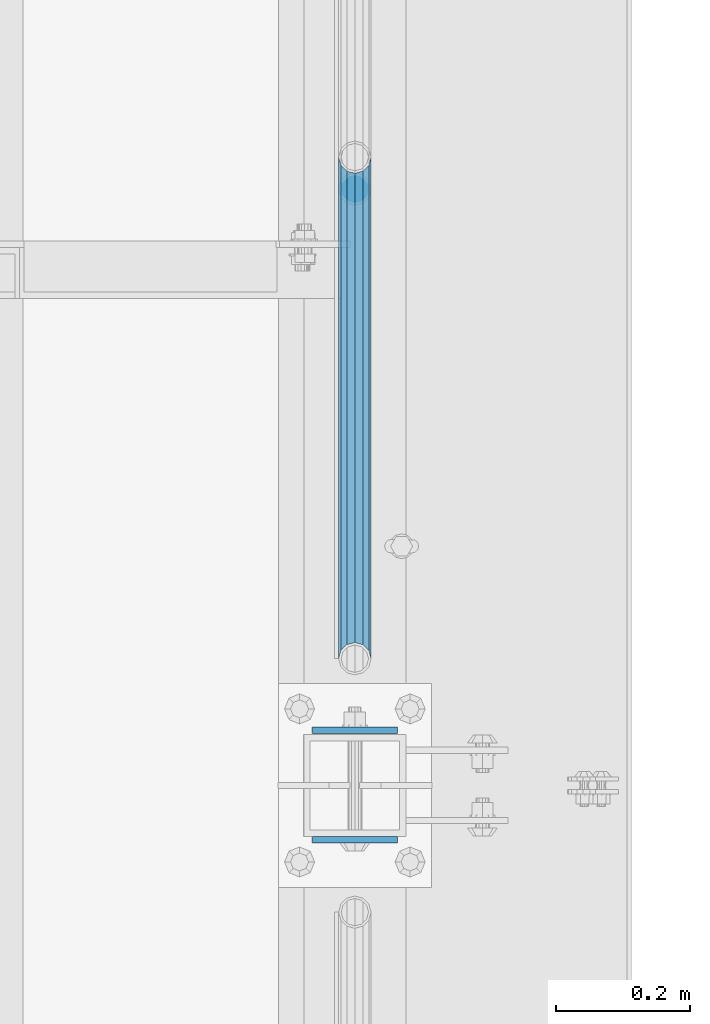
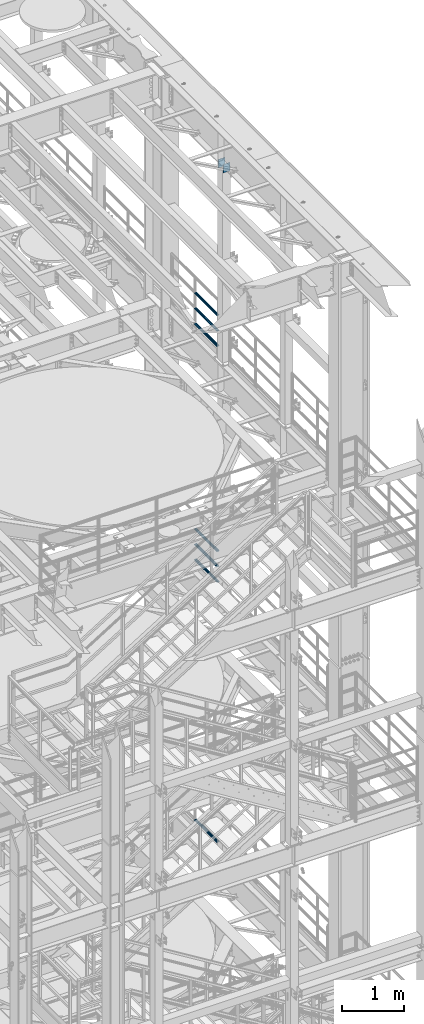
# One storey, part 1267 of 1876: 9 beams, 4 elements without a shape of their own.
"""IFC2X3 building model written with IfcOpenShell, lengths in millimetres."""

from ifc_helpers import new_model, si_unit, frame, origin_with_axes, place, context, subcontext, project, spatial, faceted_brep, material, type_object, element, aggregate, save


model = new_model("IFC2X3")

# Units and contexts
model_context = context("Model", 3, precision=1e-05, world=origin_with_axes())
body_context = subcontext(model_context, "Body", "Model", "MODEL_VIEW")
ifc_project = project(units=[si_unit("LENGTHUNIT", "METRE", prefix="MILLI"), si_unit("AREAUNIT", "SQUARE_METRE"), si_unit("VOLUMEUNIT", "CUBIC_METRE"), si_unit("MASSUNIT", "GRAM", prefix="KILO"), si_unit("TIMEUNIT", "SECOND"), si_unit("PLANEANGLEUNIT", "RADIAN"), si_unit("SOLIDANGLEUNIT", "STERADIAN"), si_unit("THERMODYNAMICTEMPERATUREUNIT", "DEGREE_CELSIUS"), si_unit("LUMINOUSINTENSITYUNIT", "LUMEN")], contexts=[model_context])

# Site, building, storey
site_placement = place(None, origin_with_axes())
site = spatial("IfcSite", under=ifc_project, at=site_placement, CompositionType="ELEMENT")
building_placement = place(site_placement, origin_with_axes())
building = spatial("IfcBuilding", under=site, at=building_placement, Name="Undefined", CompositionType="ELEMENT")
storey_placement = place(building_placement, origin_with_axes())
storey = spatial("IfcBuildingStorey", under=building, at=storey_placement, Name="Undefined", CompositionType="ELEMENT", Elevation=0.0)

# Assembly, beams
assembly_1_placement = place(storey_placement, origin_with_axes())
assembly_1 = element("IfcElementAssembly", 1, at=assembly_1_placement, inside=storey, Name="RAIL", AssemblyPlace="NOTDEFINED", PredefinedType="RIGID_FRAME")
ifc_material_1 = material()
beam_type_1 = type_object("IfcBeamType", Name="PIPE1-1/2SCH40", PredefinedType="NOTDEFINED")
beam_1_placement = place(assembly_1_placement, frame((7620.0, 430.212499999997, 18145.125), z_axis=(0.0, 0.0, 1.0), x_axis=(0.0, -1.0, 0.0)))
beam_1 = element("IfcBeam", 2, at=beam_1_placement, type_object=beam_type_1, material=ifc_material_1, Name="RAIL", ObjectType="PIPE1-1/2SCH40", context=body_context, shape_type="Brep", body=[
    faceted_brep([(728.085307006683, -12.0649999999996, 20.8971929933177), (728.085307006683, -12.0649999999996, 15.8661214311796), (727.591878568821, -10.2235000000001, 17.7076214311819), (724.852500000002, 0.0, 20.4470000000001), (724.852500000002, 0.0, 24.130000000001), (727.591878568821, 10.2235000000001, 17.7076214311819), (728.085307006683, 12.0649999999996, 15.8661214311796), (728.085307006683, 12.0649999999996, 20.8971929933177), (748.982500000002, 24.1300000000001, 0.0), (736.917500000002, 20.8971929933186, 12.0649999999987), (736.917500000002, 20.8971929933186, -12.0649999999987), (733.727928437864, 17.7076214311801, 10.2235000000001), (736.467307006683, 20.4470000000001, 0.0), (733.727928437864, 17.7076214311801, -10.2235000000001), (728.085307006683, 12.0649999999996, -15.8661214311796), (728.085307006683, 12.0649999999996, -20.8971929933177), (727.591878568821, 10.2235000000001, -17.7076214311819), (724.852500000002, 0.0, -20.4470000000001), (724.852500000002, 0.0, -24.130000000001), (728.085307006683, -12.0649999999996, -15.8661214311796), (728.085307006683, -12.0649999999996, -20.8971929933177), (727.591878568821, -10.2235000000001, -17.7076214311819), (748.982500000002, -24.1300000000001, 0.0), (736.917500000002, -20.8971929933186, -12.0649999999987), (736.917500000002, -20.8971929933186, 12.0649999999987), (733.727928437864, -17.7076214311801, -10.2235000000001), (736.467307006683, -20.4470000000001, 0.0), (733.727928437864, -17.7076214311801, 10.2235000000001), (12.0650000000064, -20.8971929933177, -12.0649999999987), (20.8971929933249, -12.0650000000005, -20.8971929933177), (0.0, 24.1299999999992, 0.0), (12.0650000000064, 20.8971929933177, -12.0649999999987), (12.0650000000064, 20.8971929933177, 12.0649999999987), (20.8971929933249, 12.0650000000005, 20.8971929933177), (24.1300000000064, 0.0, 24.130000000001), (20.8971929933249, 12.0650000000005, -20.8971929933177), (24.1300000000063, 0.0, -24.130000000001), (24.1300000000063, 0.0, -20.4470000000001), (20.8971929933249, -12.0650000000005, -15.8661214311796), (21.3906214311868, -10.2235000000001, -17.7076214311819), (21.3906214311868, 10.2235000000001, -17.7076214311819), (20.8971929933249, 12.0650000000005, -15.8661214311796), (15.2545715621445, 17.7076214311801, -10.2235000000001), (12.5151929933249, 20.4470000000001, 0.0), (15.2545715621445, 17.7076214311801, 10.2235000000001), (20.8971929933249, 12.0650000000005, 15.8661214311796), (21.3906214311868, 10.2235000000001, 17.7076214311819), (24.1300000000064, 0.0, 20.4470000000001), (21.3906214311868, -10.2235000000001, 17.7076214311819), (20.8971929933249, -12.0650000000005, 15.8661214311796), (20.8971929933249, -12.0650000000005, 20.8971929933177), (12.0650000000064, -20.8971929933177, 12.0649999999987), (0.0, -24.1299999999992, 0.0), (15.2545715621445, -17.7076214311801, 10.2235000000001), (12.5151929933249, -20.4470000000001, 0.0), (15.2545715621445, -17.7076214311801, -10.2235000000001)], [[[0, 1, 2, 3, 4]], [[4, 3, 5, 6, 7]], [[8, 9, 10]], [[7, 6, 11, 12, 13, 14, 15, 10, 9]], [[16, 17, 18, 15, 14]], [[19, 20, 18, 17, 21]], [[22, 23, 24]], [[24, 23, 20, 19, 25, 26, 27, 1, 0]], [[28, 29, 20, 23]], [[30, 31, 32]], [[33, 34, 4, 7]], [[32, 33, 7, 9]], [[30, 32, 9, 8]], [[31, 30, 8, 10]], [[35, 31, 10, 15]], [[36, 35, 15, 18]], [[29, 36, 18, 20]], [[37, 36, 29, 38, 39]], [[40, 41, 35, 36, 37]], [[32, 31, 35, 41, 42, 43, 44, 45, 33]], [[33, 45, 46, 47, 34]], [[34, 47, 48, 49, 50]], [[34, 50, 0, 4]], [[50, 51, 24, 0]], [[51, 52, 22, 24]], [[52, 28, 23, 22]], [[51, 28, 52]], [[50, 49, 53, 54, 55, 38, 29, 28, 51]], [[55, 54, 26, 25]], [[21, 39, 38, 55, 25, 19]], [[37, 39, 21, 17]], [[40, 37, 17, 16]], [[42, 41, 40, 16, 14, 13]], [[43, 42, 13, 12]], [[44, 43, 12, 11]], [[5, 46, 45, 44, 11, 6]], [[47, 46, 5, 3]], [[48, 47, 3, 2]], [[53, 49, 48, 2, 1, 27]], [[54, 53, 27, 26]]]),
])
beam_2_placement = place(assembly_1_placement, frame((7620.0, -318.770000000003, 18449.925), z_axis=(0.0, 0.0, -1.0), x_axis=(0.0, 1.0, 0.0)))
beam_2 = element("IfcBeam", 3, at=beam_2_placement, type_object=beam_type_1, material=ifc_material_1, Name="RAIL", ObjectType="PIPE1-1/2SCH40", context=body_context, shape_type="Brep", body=[
    faceted_brep([(0.0, 24.1299999999992, 0.0), (12.0650000000064, 20.8971929933177, -12.0649999999987), (12.0650000000064, 20.8971929933177, 12.0649999999987), (12.0650000000064, -20.8971929933177, 12.0649999999987), (12.0650000000064, -20.8971929933177, -12.0649999999987), (0.0, -24.1299999999992, 0.0), (20.8971929933249, -12.0650000000005, 20.8971929933177), (20.8971929933249, -12.0650000000005, 15.8661214311796), (15.2545715621445, -17.7076214311801, 10.2235000000001), (12.5151929933249, -20.4470000000001, 0.0), (15.2545715621445, -17.7076214311801, -10.2235000000001), (20.8971929933249, -12.0650000000005, -15.8661214311796), (20.8971929933249, -12.0650000000005, -20.8971929933177), (24.1300000000063, 0.0, -20.4470000000001), (24.1300000000063, 0.0, -24.130000000001), (21.3906214311868, -10.2235000000001, -17.7076214311819), (21.3906214311868, 10.2235000000001, -17.7076214311819), (20.8971929933249, 12.0650000000005, -15.8661214311796), (20.8971929933249, 12.0650000000005, -20.8971929933177), (15.2545715621445, 17.7076214311801, -10.2235000000001), (12.5151929933249, 20.4470000000001, 0.0), (15.2545715621445, 17.7076214311801, 10.2235000000001), (20.8971929933249, 12.0650000000005, 15.8661214311796), (20.8971929933249, 12.0650000000005, 20.8971929933177), (21.3906214311868, 10.2235000000001, 17.7076214311819), (24.1300000000064, 0.0, 20.4470000000001), (24.1300000000064, 0.0, 24.130000000001), (21.3906214311868, -10.2235000000001, 17.7076214311819), (748.982500000002, 24.1300000000001, 0.0), (736.917500000002, 20.8971929933186, -12.0649999999987), (728.085307006683, 12.0649999999996, -20.8971929933177), (748.982500000002, -24.1300000000001, 0.0), (736.917500000002, -20.8971929933186, -12.0649999999987), (736.917500000002, -20.8971929933186, 12.0649999999987), (728.085307006683, -12.0649999999996, 20.8971929933177), (728.085307006683, -12.0649999999996, -20.8971929933177), (724.852500000002, 0.0, -24.130000000001), (727.591878568821, 10.2235000000001, -17.7076214311819), (724.852500000002, 0.0, -20.4470000000001), (728.085307006683, 12.0649999999996, -15.8661214311796), (728.085307006683, -12.0649999999996, -15.8661214311796), (727.591878568821, -10.2235000000001, -17.7076214311819), (733.727928437864, -17.7076214311801, -10.2235000000001), (736.467307006683, -20.4470000000001, 0.0), (733.727928437864, -17.7076214311801, 10.2235000000001), (728.085307006683, -12.0649999999996, 15.8661214311796), (727.591878568821, -10.2235000000001, 17.7076214311819), (724.852500000002, 0.0, 20.4470000000001), (724.852500000002, 0.0, 24.130000000001), (728.085307006683, 12.0649999999996, 20.8971929933177), (736.917500000002, 20.8971929933186, 12.0649999999987), (728.085307006683, 12.0649999999996, 15.8661214311796), (733.727928437864, 17.7076214311801, 10.2235000000001), (736.467307006683, 20.4470000000001, 0.0), (733.727928437864, 17.7076214311801, -10.2235000000001), (727.591878568821, 10.2235000000001, 17.7076214311819)], [[[0, 1, 2]], [[3, 4, 5]], [[6, 7, 8, 9, 10, 11, 12, 4, 3]], [[13, 14, 12, 11, 15]], [[16, 17, 18, 14, 13]], [[2, 1, 18, 17, 19, 20, 21, 22, 23]], [[23, 22, 24, 25, 26]], [[26, 25, 27, 7, 6]], [[1, 0, 28, 29]], [[18, 1, 29, 30]], [[31, 32, 33]], [[6, 3, 33, 34]], [[3, 5, 31, 33]], [[5, 4, 32, 31]], [[4, 12, 35, 32]], [[12, 14, 36, 35]], [[14, 18, 30, 36]], [[37, 38, 36, 30, 39]], [[40, 35, 36, 38, 41]], [[33, 32, 35, 40, 42, 43, 44, 45, 34]], [[34, 45, 46, 47, 48]], [[26, 6, 34, 48]], [[2, 23, 49, 50]], [[23, 26, 48, 49]], [[0, 2, 50, 28]], [[28, 50, 29]], [[49, 51, 52, 53, 54, 39, 30, 29, 50]], [[48, 47, 55, 51, 49]], [[25, 24, 55, 47]], [[55, 24, 22, 21, 52, 51]], [[21, 20, 53, 52]], [[20, 19, 54, 53]], [[19, 17, 16, 37, 39, 54]], [[16, 13, 38, 37]], [[13, 15, 41, 38]], [[41, 15, 11, 10, 42, 40]], [[10, 9, 43, 42]], [[9, 8, 44, 43]], [[8, 7, 27, 46, 45, 44]], [[27, 25, 47, 46]]]),
])
beam_3_placement = place(assembly_1_placement, frame((7620.0, -318.770000000003, 18754.725), z_axis=(0.0, 0.0, -1.0), x_axis=(0.0, 1.0, 0.0)))
beam_3 = element("IfcBeam", 4, at=beam_3_placement, type_object=beam_type_1, material=ifc_material_1, Name="RAIL", ObjectType="PIPE1-1/2SCH40", context=body_context, shape_type="Brep", body=[
    faceted_brep([(0.0, 24.1299999999992, 0.0), (12.0650000000064, 20.8971929933177, -12.0649999999987), (12.0650000000064, 20.8971929933177, 12.0649999999987), (12.0650000000064, -20.8971929933177, 12.0649999999987), (12.0650000000064, -20.8971929933177, -12.0649999999987), (0.0, -24.1299999999992, 0.0), (20.8971929933249, -12.0650000000005, 20.8971929933177), (20.8971929933249, -12.0650000000005, 15.8661214311796), (15.2545715621445, -17.7076214311801, 10.2235000000001), (12.5151929933249, -20.4470000000001, 0.0), (15.2545715621445, -17.7076214311801, -10.2235000000001), (20.8971929933249, -12.0650000000005, -15.8661214311796), (20.8971929933249, -12.0650000000005, -20.8971929933177), (24.1300000000063, 0.0, -20.4470000000001), (24.1300000000063, 0.0, -24.130000000001), (21.3906214311868, -10.2235000000001, -17.7076214311819), (21.3906214311868, 10.2235000000001, -17.7076214311819), (20.8971929933249, 12.0650000000005, -15.8661214311796), (20.8971929933249, 12.0650000000005, -20.8971929933177), (15.2545715621445, 17.7076214311801, -10.2235000000001), (12.5151929933249, 20.4470000000001, 0.0), (15.2545715621445, 17.7076214311801, 10.2235000000001), (20.8971929933249, 12.0650000000005, 15.8661214311796), (20.8971929933249, 12.0650000000005, 20.8971929933177), (21.3906214311868, 10.2235000000001, 17.7076214311819), (24.1300000000064, 0.0, 20.4470000000001), (24.1300000000064, 0.0, 24.130000000001), (21.3906214311868, -10.2235000000001, 17.7076214311819), (748.982500000002, 24.1300000000001, 0.0), (736.917500000002, 20.8971929933186, -12.0649999999987), (728.085307006683, 12.0649999999996, -20.8971929933177), (748.982500000002, -24.1300000000001, 0.0), (736.917500000002, -20.8971929933186, -12.0649999999987), (736.917500000002, -20.8971929933186, 12.0649999999987), (728.085307006683, -12.0649999999996, 20.8971929933177), (728.085307006683, -12.0649999999996, -20.8971929933177), (724.852500000002, 0.0, -24.130000000001), (727.591878568821, 10.2235000000001, -17.7076214311819), (724.852500000002, 0.0, -20.4470000000001), (728.085307006683, 12.0649999999996, -15.8661214311796), (728.085307006683, -12.0649999999996, -15.8661214311796), (727.591878568821, -10.2235000000001, -17.7076214311819), (733.727928437864, -17.7076214311801, -10.2235000000001), (736.467307006683, -20.4470000000001, 0.0), (733.727928437864, -17.7076214311801, 10.2235000000001), (728.085307006683, -12.0649999999996, 15.8661214311796), (727.591878568821, -10.2235000000001, 17.7076214311819), (724.852500000002, 0.0, 20.4470000000001), (724.852500000002, 0.0, 24.130000000001), (728.085307006683, 12.0649999999996, 20.8971929933177), (736.917500000002, 20.8971929933186, 12.0649999999987), (728.085307006683, 12.0649999999996, 15.8661214311796), (733.727928437864, 17.7076214311801, 10.2235000000001), (736.467307006683, 20.4470000000001, 0.0), (733.727928437864, 17.7076214311801, -10.2235000000001), (727.591878568821, 10.2235000000001, 17.7076214311819)], [[[0, 1, 2]], [[3, 4, 5]], [[6, 7, 8, 9, 10, 11, 12, 4, 3]], [[13, 14, 12, 11, 15]], [[16, 17, 18, 14, 13]], [[2, 1, 18, 17, 19, 20, 21, 22, 23]], [[23, 22, 24, 25, 26]], [[26, 25, 27, 7, 6]], [[1, 0, 28, 29]], [[18, 1, 29, 30]], [[31, 32, 33]], [[6, 3, 33, 34]], [[3, 5, 31, 33]], [[5, 4, 32, 31]], [[4, 12, 35, 32]], [[12, 14, 36, 35]], [[14, 18, 30, 36]], [[37, 38, 36, 30, 39]], [[40, 35, 36, 38, 41]], [[33, 32, 35, 40, 42, 43, 44, 45, 34]], [[34, 45, 46, 47, 48]], [[26, 6, 34, 48]], [[2, 23, 49, 50]], [[23, 26, 48, 49]], [[0, 2, 50, 28]], [[28, 50, 29]], [[49, 51, 52, 53, 54, 39, 30, 29, 50]], [[48, 47, 55, 51, 49]], [[25, 24, 55, 47]], [[55, 24, 22, 21, 52, 51]], [[21, 20, 53, 52]], [[20, 19, 54, 53]], [[19, 17, 16, 37, 39, 54]], [[16, 13, 38, 37]], [[13, 15, 41, 38]], [[41, 15, 11, 10, 42, 40]], [[10, 9, 43, 42]], [[9, 8, 44, 43]], [[8, 7, 27, 46, 45, 44]], [[27, 25, 47, 46]]]),
])
aggregate(assembly_1, [beam_1, beam_2, beam_3])

assembly_2_placement = place(storey_placement, origin_with_axes())
assembly_2 = element("IfcElementAssembly", 5, at=assembly_2_placement, inside=storey, Name="RAIL", AssemblyPlace="NOTDEFINED", PredefinedType="RIGID_FRAME")
beam_4_placement = place(assembly_2_placement, frame((7620.0, 430.212499999995, 13471.525), z_axis=(0.0, 0.0, 1.0), x_axis=(0.0, -1.0, 0.0)))
beam_4 = element("IfcBeam", 6, at=beam_4_placement, type_object=beam_type_1, material=ifc_material_1, Name="RAIL", ObjectType="PIPE1-1/2SCH40", context=body_context, shape_type="Brep", body=[
    faceted_brep([(728.085307006683, -12.0649999999996, 20.8971929933177), (728.085307006683, -12.0649999999996, 15.8661214311796), (727.591878568821, -10.2235000000001, 17.7076214311819), (724.852500000002, 0.0, 20.4470000000001), (724.852500000002, 0.0, 24.130000000001), (727.591878568821, 10.2235000000001, 17.7076214311819), (728.085307006683, 12.0649999999996, 15.8661214311796), (728.085307006683, 12.0649999999996, 20.8971929933177), (748.982500000002, 24.1300000000001, 0.0), (736.917500000002, 20.8971929933186, 12.0649999999987), (736.917500000002, 20.8971929933186, -12.0649999999987), (733.727928437864, 17.7076214311801, 10.2235000000001), (736.467307006683, 20.4470000000001, 0.0), (733.727928437864, 17.7076214311801, -10.2235000000001), (728.085307006683, 12.0649999999996, -15.8661214311796), (728.085307006683, 12.0649999999996, -20.8971929933177), (727.591878568821, 10.2235000000001, -17.7076214311819), (724.852500000002, 0.0, -20.4470000000001), (724.852500000002, 0.0, -24.130000000001), (728.085307006683, -12.0649999999996, -15.8661214311796), (728.085307006683, -12.0649999999996, -20.8971929933177), (727.591878568821, -10.2235000000001, -17.7076214311819), (748.982500000002, -24.1300000000001, 0.0), (736.917500000002, -20.8971929933186, -12.0649999999987), (736.917500000002, -20.8971929933186, 12.0649999999987), (733.727928437864, -17.7076214311801, -10.2235000000001), (736.467307006683, -20.4470000000001, 0.0), (733.727928437864, -17.7076214311801, 10.2235000000001), (12.0650000000064, -20.8971929933177, -12.0649999999987), (20.8971929933249, -12.0650000000005, -20.8971929933177), (0.0, 24.1299999999992, 0.0), (12.0650000000064, 20.8971929933177, -12.0649999999987), (12.0650000000064, 20.8971929933177, 12.0649999999987), (20.8971929933249, 12.0650000000005, 20.8971929933177), (24.1300000000064, 0.0, 24.130000000001), (20.8971929933249, 12.0650000000005, -20.8971929933177), (24.1300000000063, 0.0, -24.130000000001), (24.1300000000063, 0.0, -20.4470000000001), (20.8971929933249, -12.0650000000005, -15.8661214311796), (21.3906214311868, -10.2235000000001, -17.7076214311819), (21.3906214311868, 10.2235000000001, -17.7076214311819), (20.8971929933249, 12.0650000000005, -15.8661214311796), (15.2545715621445, 17.7076214311801, -10.2235000000001), (12.5151929933249, 20.4470000000001, 0.0), (15.2545715621445, 17.7076214311801, 10.2235000000001), (20.8971929933249, 12.0650000000005, 15.8661214311796), (21.3906214311868, 10.2235000000001, 17.7076214311819), (24.1300000000064, 0.0, 20.4470000000001), (21.3906214311868, -10.2235000000001, 17.7076214311819), (20.8971929933249, -12.0650000000005, 15.8661214311796), (20.8971929933249, -12.0650000000005, 20.8971929933177), (12.0650000000064, -20.8971929933177, 12.0649999999987), (0.0, -24.1299999999992, 0.0), (15.2545715621445, -17.7076214311801, 10.2235000000001), (12.5151929933249, -20.4470000000001, 0.0), (15.2545715621445, -17.7076214311801, -10.2235000000001)], [[[0, 1, 2, 3, 4]], [[4, 3, 5, 6, 7]], [[8, 9, 10]], [[7, 6, 11, 12, 13, 14, 15, 10, 9]], [[16, 17, 18, 15, 14]], [[19, 20, 18, 17, 21]], [[22, 23, 24]], [[24, 23, 20, 19, 25, 26, 27, 1, 0]], [[28, 29, 20, 23]], [[30, 31, 32]], [[33, 34, 4, 7]], [[32, 33, 7, 9]], [[30, 32, 9, 8]], [[31, 30, 8, 10]], [[35, 31, 10, 15]], [[36, 35, 15, 18]], [[29, 36, 18, 20]], [[37, 36, 29, 38, 39]], [[40, 41, 35, 36, 37]], [[32, 31, 35, 41, 42, 43, 44, 45, 33]], [[33, 45, 46, 47, 34]], [[34, 47, 48, 49, 50]], [[34, 50, 0, 4]], [[50, 51, 24, 0]], [[51, 52, 22, 24]], [[52, 28, 23, 22]], [[51, 28, 52]], [[50, 49, 53, 54, 55, 38, 29, 28, 51]], [[55, 54, 26, 25]], [[21, 39, 38, 55, 25, 19]], [[37, 39, 21, 17]], [[40, 37, 17, 16]], [[42, 41, 40, 16, 14, 13]], [[43, 42, 13, 12]], [[44, 43, 12, 11]], [[5, 46, 45, 44, 11, 6]], [[47, 46, 5, 3]], [[48, 47, 3, 2]], [[53, 49, 48, 2, 1, 27]], [[54, 53, 27, 26]]]),
])
beam_5_placement = place(assembly_2_placement, frame((7620.0, -318.770000000005, 13776.325), z_axis=(0.0, 0.0, -1.0), x_axis=(0.0, 1.0, 0.0)))
beam_5 = element("IfcBeam", 7, at=beam_5_placement, type_object=beam_type_1, material=ifc_material_1, Name="RAIL", ObjectType="PIPE1-1/2SCH40", context=body_context, shape_type="Brep", body=[
    faceted_brep([(0.0, 24.1299999999992, 0.0), (12.0650000000064, 20.8971929933177, -12.0649999999987), (12.0650000000064, 20.8971929933177, 12.0649999999987), (12.0650000000064, -20.8971929933177, 12.0649999999987), (12.0650000000064, -20.8971929933177, -12.0649999999987), (0.0, -24.1299999999992, 0.0), (20.8971929933249, -12.0650000000005, 20.8971929933177), (20.8971929933249, -12.0650000000005, 15.8661214311796), (15.2545715621445, -17.7076214311801, 10.2235000000001), (12.5151929933249, -20.4470000000001, 0.0), (15.2545715621445, -17.7076214311801, -10.2235000000001), (20.8971929933249, -12.0650000000005, -15.8661214311796), (20.8971929933249, -12.0650000000005, -20.8971929933177), (24.1300000000063, 0.0, -20.4470000000001), (24.1300000000063, 0.0, -24.130000000001), (21.3906214311868, -10.2235000000001, -17.7076214311819), (21.3906214311868, 10.2235000000001, -17.7076214311819), (20.8971929933249, 12.0650000000005, -15.8661214311796), (20.8971929933249, 12.0650000000005, -20.8971929933177), (15.2545715621445, 17.7076214311801, -10.2235000000001), (12.5151929933249, 20.4470000000001, 0.0), (15.2545715621445, 17.7076214311801, 10.2235000000001), (20.8971929933249, 12.0650000000005, 15.8661214311796), (20.8971929933249, 12.0650000000005, 20.8971929933177), (21.3906214311868, 10.2235000000001, 17.7076214311819), (24.1300000000064, 0.0, 20.4470000000001), (24.1300000000064, 0.0, 24.130000000001), (21.3906214311868, -10.2235000000001, 17.7076214311819), (748.982500000002, 24.1300000000001, 0.0), (736.917500000002, 20.8971929933186, -12.0649999999987), (728.085307006683, 12.0649999999996, -20.8971929933177), (748.982500000002, -24.1300000000001, 0.0), (736.917500000002, -20.8971929933186, -12.0649999999987), (736.917500000002, -20.8971929933186, 12.0649999999987), (728.085307006683, -12.0649999999996, 20.8971929933177), (728.085307006683, -12.0649999999996, -20.8971929933177), (724.852500000002, 0.0, -24.130000000001), (727.591878568821, 10.2235000000001, -17.7076214311819), (724.852500000002, 0.0, -20.4470000000001), (728.085307006683, 12.0649999999996, -15.8661214311796), (728.085307006683, -12.0649999999996, -15.8661214311796), (727.591878568821, -10.2235000000001, -17.7076214311819), (733.727928437864, -17.7076214311801, -10.2235000000001), (736.467307006683, -20.4470000000001, 0.0), (733.727928437864, -17.7076214311801, 10.2235000000001), (728.085307006683, -12.0649999999996, 15.8661214311796), (727.591878568821, -10.2235000000001, 17.7076214311819), (724.852500000002, 0.0, 20.4470000000001), (724.852500000002, 0.0, 24.130000000001), (728.085307006683, 12.0649999999996, 20.8971929933177), (736.917500000002, 20.8971929933186, 12.0649999999987), (728.085307006683, 12.0649999999996, 15.8661214311796), (733.727928437864, 17.7076214311801, 10.2235000000001), (736.467307006683, 20.4470000000001, 0.0), (733.727928437864, 17.7076214311801, -10.2235000000001), (727.591878568821, 10.2235000000001, 17.7076214311819)], [[[0, 1, 2]], [[3, 4, 5]], [[6, 7, 8, 9, 10, 11, 12, 4, 3]], [[13, 14, 12, 11, 15]], [[16, 17, 18, 14, 13]], [[2, 1, 18, 17, 19, 20, 21, 22, 23]], [[23, 22, 24, 25, 26]], [[26, 25, 27, 7, 6]], [[1, 0, 28, 29]], [[18, 1, 29, 30]], [[31, 32, 33]], [[6, 3, 33, 34]], [[3, 5, 31, 33]], [[5, 4, 32, 31]], [[4, 12, 35, 32]], [[12, 14, 36, 35]], [[14, 18, 30, 36]], [[37, 38, 36, 30, 39]], [[40, 35, 36, 38, 41]], [[33, 32, 35, 40, 42, 43, 44, 45, 34]], [[34, 45, 46, 47, 48]], [[26, 6, 34, 48]], [[2, 23, 49, 50]], [[23, 26, 48, 49]], [[0, 2, 50, 28]], [[28, 50, 29]], [[49, 51, 52, 53, 54, 39, 30, 29, 50]], [[48, 47, 55, 51, 49]], [[25, 24, 55, 47]], [[55, 24, 22, 21, 52, 51]], [[21, 20, 53, 52]], [[20, 19, 54, 53]], [[19, 17, 16, 37, 39, 54]], [[16, 13, 38, 37]], [[13, 15, 41, 38]], [[41, 15, 11, 10, 42, 40]], [[10, 9, 43, 42]], [[9, 8, 44, 43]], [[8, 7, 27, 46, 45, 44]], [[27, 25, 47, 46]]]),
])
beam_6_placement = place(assembly_2_placement, frame((7620.0, -318.770000000005, 14081.125), z_axis=(0.0, 0.0, -1.0), x_axis=(0.0, 1.0, 0.0)))
beam_6 = element("IfcBeam", 8, at=beam_6_placement, type_object=beam_type_1, material=ifc_material_1, Name="RAIL", ObjectType="PIPE1-1/2SCH40", context=body_context, shape_type="Brep", body=[
    faceted_brep([(0.0, 24.1299999999992, 0.0), (12.0650000000064, 20.8971929933177, -12.0649999999987), (12.0650000000064, 20.8971929933177, 12.0649999999987), (12.0650000000064, -20.8971929933177, 12.0649999999987), (12.0650000000064, -20.8971929933177, -12.0649999999987), (0.0, -24.1299999999992, 0.0), (20.8971929933249, -12.0650000000005, 20.8971929933177), (20.8971929933249, -12.0650000000005, 15.8661214311796), (15.2545715621445, -17.7076214311801, 10.2235000000001), (12.5151929933249, -20.4470000000001, 0.0), (15.2545715621445, -17.7076214311801, -10.2235000000001), (20.8971929933249, -12.0650000000005, -15.8661214311796), (20.8971929933249, -12.0650000000005, -20.8971929933177), (24.1300000000063, 0.0, -20.4470000000001), (24.1300000000063, 0.0, -24.130000000001), (21.3906214311868, -10.2235000000001, -17.7076214311819), (21.3906214311868, 10.2235000000001, -17.7076214311819), (20.8971929933249, 12.0650000000005, -15.8661214311796), (20.8971929933249, 12.0650000000005, -20.8971929933177), (15.2545715621445, 17.7076214311801, -10.2235000000001), (12.5151929933249, 20.4470000000001, 0.0), (15.2545715621445, 17.7076214311801, 10.2235000000001), (20.8971929933249, 12.0650000000005, 15.8661214311796), (20.8971929933249, 12.0650000000005, 20.8971929933177), (21.3906214311868, 10.2235000000001, 17.7076214311819), (24.1300000000064, 0.0, 20.4470000000001), (24.1300000000064, 0.0, 24.130000000001), (21.3906214311868, -10.2235000000001, 17.7076214311819), (748.982500000002, 24.1300000000001, 0.0), (736.917500000002, 20.8971929933186, -12.0649999999987), (728.085307006683, 12.0649999999996, -20.8971929933177), (748.982500000002, -24.1300000000001, 0.0), (736.917500000002, -20.8971929933186, -12.0649999999987), (736.917500000002, -20.8971929933186, 12.0649999999987), (728.085307006683, -12.0649999999996, 20.8971929933177), (728.085307006683, -12.0649999999996, -20.8971929933177), (724.852500000002, 0.0, -24.130000000001), (727.591878568821, 10.2235000000001, -17.7076214311819), (724.852500000002, 0.0, -20.4470000000001), (728.085307006683, 12.0649999999996, -15.8661214311796), (728.085307006683, -12.0649999999996, -15.8661214311796), (727.591878568821, -10.2235000000001, -17.7076214311819), (733.727928437864, -17.7076214311801, -10.2235000000001), (736.467307006683, -20.4470000000001, 0.0), (733.727928437864, -17.7076214311801, 10.2235000000001), (728.085307006683, -12.0649999999996, 15.8661214311796), (727.591878568821, -10.2235000000001, 17.7076214311819), (724.852500000002, 0.0, 20.4470000000001), (724.852500000002, 0.0, 24.130000000001), (728.085307006683, 12.0649999999996, 20.8971929933177), (736.917500000002, 20.8971929933186, 12.0649999999987), (728.085307006683, 12.0649999999996, 15.8661214311796), (733.727928437864, 17.7076214311801, 10.2235000000001), (736.467307006683, 20.4470000000001, 0.0), (733.727928437864, 17.7076214311801, -10.2235000000001), (727.591878568821, 10.2235000000001, 17.7076214311819)], [[[0, 1, 2]], [[3, 4, 5]], [[6, 7, 8, 9, 10, 11, 12, 4, 3]], [[13, 14, 12, 11, 15]], [[16, 17, 18, 14, 13]], [[2, 1, 18, 17, 19, 20, 21, 22, 23]], [[23, 22, 24, 25, 26]], [[26, 25, 27, 7, 6]], [[1, 0, 28, 29]], [[18, 1, 29, 30]], [[31, 32, 33]], [[6, 3, 33, 34]], [[3, 5, 31, 33]], [[5, 4, 32, 31]], [[4, 12, 35, 32]], [[12, 14, 36, 35]], [[14, 18, 30, 36]], [[37, 38, 36, 30, 39]], [[40, 35, 36, 38, 41]], [[33, 32, 35, 40, 42, 43, 44, 45, 34]], [[34, 45, 46, 47, 48]], [[26, 6, 34, 48]], [[2, 23, 49, 50]], [[23, 26, 48, 49]], [[0, 2, 50, 28]], [[28, 50, 29]], [[49, 51, 52, 53, 54, 39, 30, 29, 50]], [[48, 47, 55, 51, 49]], [[25, 24, 55, 47]], [[55, 24, 22, 21, 52, 51]], [[21, 20, 53, 52]], [[20, 19, 54, 53]], [[19, 17, 16, 37, 39, 54]], [[16, 13, 38, 37]], [[13, 15, 41, 38]], [[41, 15, 11, 10, 42, 40]], [[10, 9, 43, 42]], [[9, 8, 44, 43]], [[8, 7, 27, 46, 45, 44]], [[27, 25, 47, 46]]]),
])
aggregate(assembly_2, [beam_4, beam_5, beam_6])

# Assembly, beam
assembly_3_placement = place(storey_placement, origin_with_axes())
assembly_3 = element("IfcElementAssembly", 9, at=assembly_3_placement, inside=storey, Name="RAIL", AssemblyPlace="NOTDEFINED", PredefinedType="RIGID_FRAME")
beam_7_placement = place(assembly_3_placement, frame((7620.0, 430.212499999999, 8315.325), z_axis=(0.0, 0.0, 1.0), x_axis=(0.0, -1.0, 0.0)))
beam_7 = element("IfcBeam", 10, at=beam_7_placement, type_object=beam_type_1, material=ifc_material_1, Name="RAIL", ObjectType="PIPE1-1/2SCH40", context=body_context, shape_type="Brep", body=[
    faceted_brep([(728.085307006683, -12.0649999999996, 20.8971929933177), (728.085307006683, -12.0649999999996, 15.8661214311796), (727.591878568821, -10.2235000000001, 17.7076214311819), (724.852500000002, 0.0, 20.4470000000001), (724.852500000002, 0.0, 24.130000000001), (727.591878568821, 10.2235000000001, 17.7076214311819), (728.085307006683, 12.0649999999996, 15.8661214311796), (728.085307006683, 12.0649999999996, 20.8971929933177), (748.982500000002, 24.1300000000001, 0.0), (736.917500000002, 20.8971929933186, 12.0649999999987), (736.917500000002, 20.8971929933186, -12.0649999999987), (733.727928437864, 17.7076214311801, 10.2235000000001), (736.467307006683, 20.4470000000001, 0.0), (733.727928437864, 17.7076214311801, -10.2235000000001), (728.085307006683, 12.0649999999996, -15.8661214311796), (728.085307006683, 12.0649999999996, -20.8971929933177), (727.591878568821, 10.2235000000001, -17.7076214311819), (724.852500000002, 0.0, -20.4470000000001), (724.852500000002, 0.0, -24.130000000001), (728.085307006683, -12.0649999999996, -15.8661214311796), (728.085307006683, -12.0649999999996, -20.8971929933177), (727.591878568821, -10.2235000000001, -17.7076214311819), (748.982500000002, -24.1300000000001, 0.0), (736.917500000002, -20.8971929933186, -12.0649999999987), (736.917500000002, -20.8971929933186, 12.0649999999987), (733.727928437864, -17.7076214311801, -10.2235000000001), (736.467307006683, -20.4470000000001, 0.0), (733.727928437864, -17.7076214311801, 10.2235000000001), (12.0650000000064, -20.8971929933177, -12.0649999999987), (20.8971929933249, -12.0650000000005, -20.8971929933177), (0.0, 24.1299999999992, 0.0), (12.0650000000064, 20.8971929933177, -12.0649999999987), (12.0650000000064, 20.8971929933177, 12.0649999999987), (20.8971929933249, 12.0650000000005, 20.8971929933177), (24.1300000000064, 0.0, 24.130000000001), (20.8971929933249, 12.0650000000005, -20.8971929933177), (24.1300000000063, 0.0, -24.130000000001), (24.1300000000063, 0.0, -20.4470000000001), (20.8971929933249, -12.0650000000005, -15.8661214311796), (21.3906214311868, -10.2235000000001, -17.7076214311819), (21.3906214311868, 10.2235000000001, -17.7076214311819), (20.8971929933249, 12.0650000000005, -15.8661214311796), (15.2545715621445, 17.7076214311801, -10.2235000000001), (12.5151929933249, 20.4470000000001, 0.0), (15.2545715621445, 17.7076214311801, 10.2235000000001), (20.8971929933249, 12.0650000000005, 15.8661214311796), (21.3906214311868, 10.2235000000001, 17.7076214311819), (24.1300000000064, 0.0, 20.4470000000001), (21.3906214311868, -10.2235000000001, 17.7076214311819), (20.8971929933249, -12.0650000000005, 15.8661214311796), (20.8971929933249, -12.0650000000005, 20.8971929933177), (12.0650000000064, -20.8971929933177, 12.0649999999987), (0.0, -24.1299999999992, 0.0), (15.2545715621445, -17.7076214311801, 10.2235000000001), (12.5151929933249, -20.4470000000001, 0.0), (15.2545715621445, -17.7076214311801, -10.2235000000001)], [[[0, 1, 2, 3, 4]], [[4, 3, 5, 6, 7]], [[8, 9, 10]], [[7, 6, 11, 12, 13, 14, 15, 10, 9]], [[16, 17, 18, 15, 14]], [[19, 20, 18, 17, 21]], [[22, 23, 24]], [[24, 23, 20, 19, 25, 26, 27, 1, 0]], [[28, 29, 20, 23]], [[30, 31, 32]], [[33, 34, 4, 7]], [[32, 33, 7, 9]], [[30, 32, 9, 8]], [[31, 30, 8, 10]], [[35, 31, 10, 15]], [[36, 35, 15, 18]], [[29, 36, 18, 20]], [[37, 36, 29, 38, 39]], [[40, 41, 35, 36, 37]], [[32, 31, 35, 41, 42, 43, 44, 45, 33]], [[33, 45, 46, 47, 34]], [[34, 47, 48, 49, 50]], [[34, 50, 0, 4]], [[50, 51, 24, 0]], [[51, 52, 22, 24]], [[52, 28, 23, 22]], [[51, 28, 52]], [[50, 49, 53, 54, 55, 38, 29, 28, 51]], [[55, 54, 26, 25]], [[21, 39, 38, 55, 25, 19]], [[37, 39, 21, 17]], [[40, 37, 17, 16]], [[42, 41, 40, 16, 14, 13]], [[43, 42, 13, 12]], [[44, 43, 12, 11]], [[5, 46, 45, 44, 11, 6]], [[47, 46, 5, 3]], [[48, 47, 3, 2]], [[53, 49, 48, 2, 1, 27]], [[54, 53, 27, 26]]]),
])
aggregate(assembly_3, [beam_7])

# Assembly, beams
assembly_4_placement = place(storey_placement, origin_with_axes())
assembly_4 = element("IfcElementAssembly", 11, at=assembly_4_placement, inside=storey, Name="BEAM", AssemblyPlace="NOTDEFINED", PredefinedType="RIGID_FRAME")
ifc_material_2 = material(Name="STEEL/A36")
beam_type_2 = type_object("IfcBeamType", PredefinedType="NOTDEFINED")
beam_8_placement = place(assembly_4_placement, frame((7556.5, -425.450000000001, 21850.35), z_axis=(0.0, 0.0, -1.0), x_axis=(1.0, 0.0, 0.0)))
beam_8 = element("IfcBeam", 12, at=beam_8_placement, type_object=beam_type_2, material=ifc_material_2, Name="PLATE", context=body_context, shape_type="Brep", body=[
    faceted_brep([(0.0, 4.76249999999982, -82.5499999999993), (0.0, 4.76249999999982, 82.5499999999993), (127.0, 4.76249999999982, 82.5499999999993), (127.0, 4.76249999999982, -82.5499999999993), (0.0, -4.76249999999982, 82.5499999999993), (127.0, -4.76249999999982, 82.5499999999993), (0.0, -4.76249999999982, -82.5499999999993), (127.0, -4.76249999999982, -82.5499999999993)], [[[0, 1, 2, 3]], [[1, 4, 5, 2]], [[4, 6, 7, 5]], [[6, 0, 3, 7]], [[5, 7, 3, 2]], [[6, 4, 1, 0]]]),
])
beam_9_placement = place(assembly_4_placement, frame((7556.5, -588.9625, 21850.35), z_axis=(0.0, 0.0, -1.0), x_axis=(1.0, 0.0, 0.0)))
beam_9 = element("IfcBeam", 13, at=beam_9_placement, type_object=beam_type_2, material=ifc_material_2, Name="PLATE", context=body_context, shape_type="Brep", body=[
    faceted_brep([(0.0, 4.76249999999982, -82.5499999999993), (0.0, 4.76249999999982, 82.5499999999993), (127.0, 4.76249999999982, 82.5499999999993), (127.0, 4.76249999999982, -82.5499999999993), (0.0, -4.76249999999982, 82.5499999999993), (127.0, -4.76249999999982, 82.5499999999993), (0.0, -4.76249999999982, -82.5499999999993), (127.0, -4.76249999999982, -82.5499999999993)], [[[0, 1, 2, 3]], [[1, 4, 5, 2]], [[4, 6, 7, 5]], [[6, 0, 3, 7]], [[5, 7, 3, 2]], [[6, 4, 1, 0]]]),
])
aggregate(assembly_4, [beam_8, beam_9])

save(model, "model.ifc")
